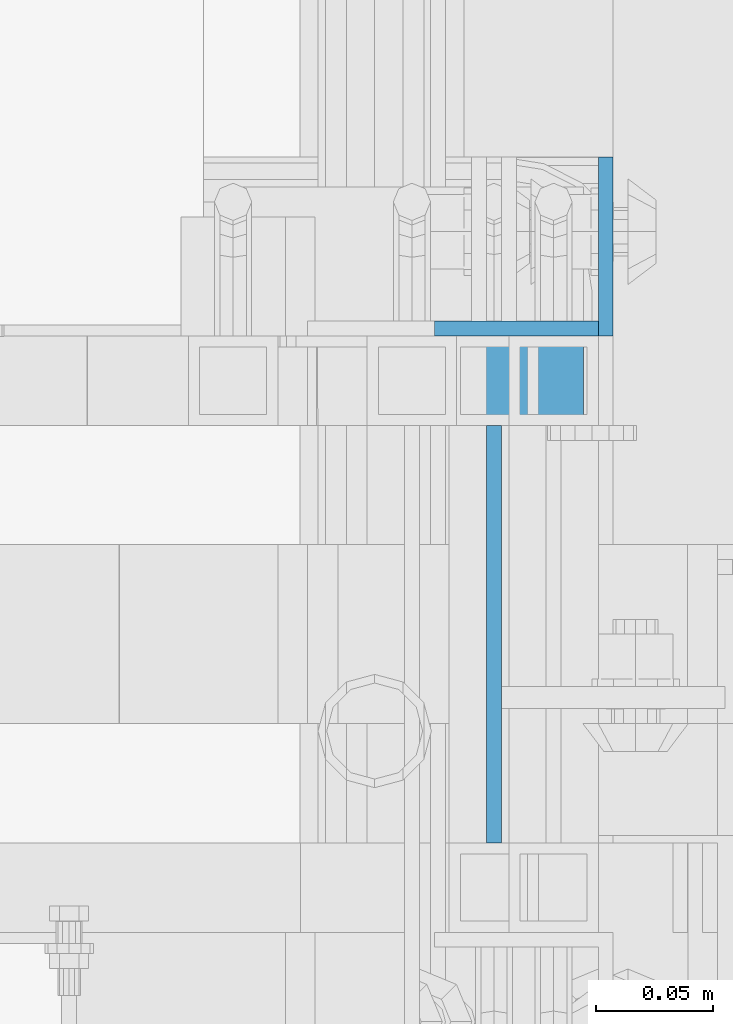
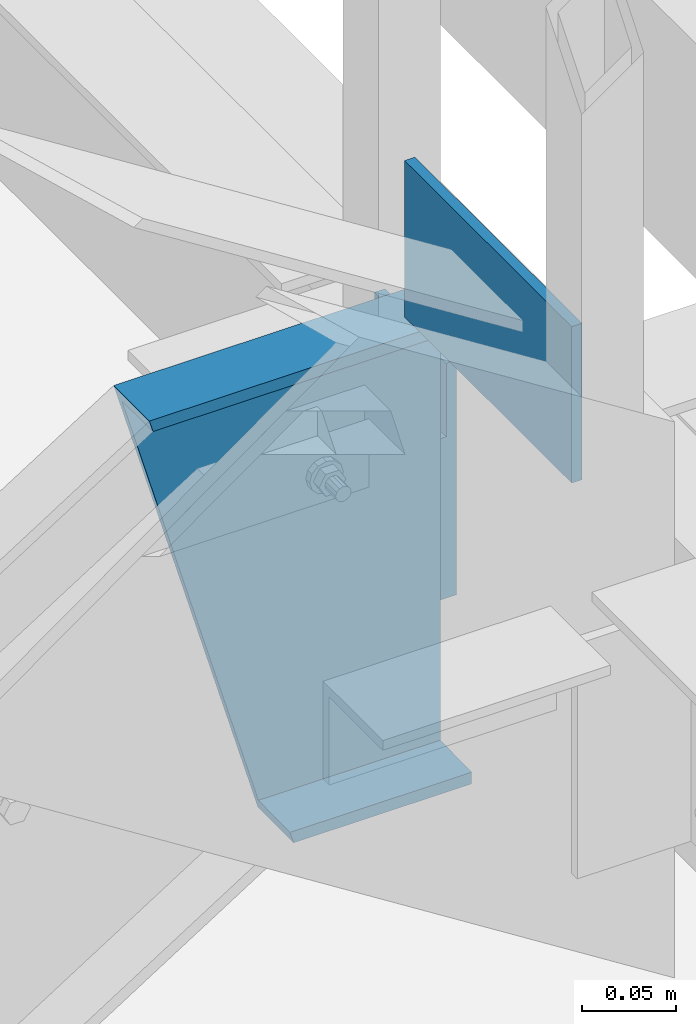
# One storey, part 1200 of 1876: 3 beams, 2 elements without a shape of their own.
"""IFC2X3 building model written with IfcOpenShell, lengths in millimetres."""

from ifc_helpers import new_model, si_unit, frame, origin_with_axes, place, context, subcontext, project, spatial, faceted_brep, material, type_object, element, aggregate, save


model = new_model("IFC2X3")

# Units and contexts
model_context = context("Model", 3, precision=1e-05, world=origin_with_axes())
body_context = subcontext(model_context, "Body", "Model", "MODEL_VIEW")
ifc_project = project(units=[si_unit("LENGTHUNIT", "METRE", prefix="MILLI"), si_unit("AREAUNIT", "SQUARE_METRE"), si_unit("VOLUMEUNIT", "CUBIC_METRE"), si_unit("MASSUNIT", "GRAM", prefix="KILO"), si_unit("TIMEUNIT", "SECOND"), si_unit("PLANEANGLEUNIT", "RADIAN"), si_unit("SOLIDANGLEUNIT", "STERADIAN"), si_unit("THERMODYNAMICTEMPERATUREUNIT", "DEGREE_CELSIUS"), si_unit("LUMINOUSINTENSITYUNIT", "LUMEN")], contexts=[model_context])

# Site, building, storey
site_placement = place(None, origin_with_axes())
site = spatial("IfcSite", under=ifc_project, at=site_placement, CompositionType="ELEMENT")
building_placement = place(site_placement, origin_with_axes())
building = spatial("IfcBuilding", under=site, at=building_placement, Name="Undefined", CompositionType="ELEMENT")
storey_placement = place(building_placement, origin_with_axes())
storey = spatial("IfcBuildingStorey", under=building, at=storey_placement, Name="Undefined", CompositionType="ELEMENT", Elevation=0.0)

# Assembly, beam
assembly_1_placement = place(storey_placement, origin_with_axes())
assembly_1 = element("IfcElementAssembly", 1, at=assembly_1_placement, inside=storey, Name="RAIL", AssemblyPlace="NOTDEFINED", PredefinedType="RIGID_FRAME")
ifc_material = material(Name="STEEL/A36")
beam_type_1 = type_object("IfcBeamType", PredefinedType="NOTDEFINED")
beam_1_placement = place(assembly_1_placement, frame((6248.39999930583, -5753.10000038053, 2393.18362061127), z_axis=(0.0, 0.0, 1.0), x_axis=(0.0, -1.0, 0.0)))
beam_1 = element("IfcBeam", 2, at=beam_1_placement, type_object=beam_type_1, material=ifc_material, Name="PLATE", context=body_context, shape_type="Brep", body=[
    faceted_brep([(0.0, 3.17500000000018, -50.8000000000002), (0.0, 3.17500000000018, 50.8000000000002), (177.799998770143, 3.1750000000111, 50.8000000000866), (177.799998770101, 3.1750000000111, -50.7999999999138), (0.0, -3.17500000000018, 50.8000000000002), (177.799998770144, -3.17499999998881, 50.8000000000866), (0.0, -3.17500000000018, -50.8000000000002), (177.799998770101, -3.17499999998881, -50.7999999999138)], [[[0, 1, 2, 3]], [[1, 4, 5, 2]], [[4, 6, 7, 5]], [[6, 0, 3, 7]], [[5, 7, 3, 2]], [[6, 4, 1, 0]]]),
])
aggregate(assembly_1, [beam_1])

# Assembly, beams
assembly_2_placement = place(storey_placement, origin_with_axes())
assembly_2 = element("IfcElementAssembly", 3, at=assembly_2_placement, inside=storey, Name="STRINGER", AssemblyPlace="NOTDEFINED", PredefinedType="RIGID_FRAME")
beam_type_2 = type_object("IfcBeamType", Name="L3X3X1/4", PredefinedType="NOTDEFINED")
beam_2_placement = place(assembly_2_placement, frame((6261.10000038163, -5676.90000121077, 2272.53362013306), z_axis=(-1.0, 0.0, 0.0), x_axis=(0.0, 0.0, -1.0)))
beam_2 = element("IfcBeam", 4, at=beam_2_placement, type_object=beam_type_2, material=ifc_material, Name="ANGLE", ObjectType="L3X3X1/4", context=body_context, shape_type="Brep", body=[
    faceted_brep([(47.6249994560144, 31.75, -31.75), (47.6249994560144, 38.1000000000004, -31.7499988043019), (0.0, 38.1000000000004, -31.7499984732442), (0.0, 31.75, -31.75), (47.6249994434002, 31.75, 38.0999996698192), (47.6249994434002, 38.1000000000004, 38.1000000000004), (152.4, 31.75, -31.75), (152.4, 31.75, 38.0999999999999), (0.0, -38.1000000000004, -31.75), (0.0, -38.1000000000004, -38.1), (152.4, -38.1000000000004, -38.1), (152.4, -38.1000000000004, -31.75), (0.0, 38.1000000000004, -38.1), (152.4, 38.1000000000004, -38.1), (152.4, 38.1000000000004, 38.1), (0.0, -15.5999984947448, -31.75)], [[[0, 1, 2, 3]], [[4, 5, 1, 0]], [[6, 7, 4, 0]], [[8, 9, 10, 11]], [[9, 12, 13, 10]], [[7, 6, 11, 10, 13, 14]], [[0, 3, 15, 8, 11, 6]], [[12, 9, 8, 15, 3, 2]], [[14, 13, 12, 2, 1, 5]], [[7, 14, 5, 4]]]),
])
beam_type_3 = type_object("IfcBeamType", Name="MC12X10.6", PredefinedType="NOTDEFINED")
beam_3_placement = place(assembly_2_placement, frame((6088.62272863529, -5734.05000121077, 2177.28362013306), z_axis=(0.0, 0.0, 1.0), x_axis=(1.0, 0.0, 0.0)))
beam_3 = element("IfcBeam", 5, at=beam_3_placement, type_object=beam_type_3, material=ifc_material, Name="STRINGER", ObjectType="MC12X10.6", context=body_context, shape_type="Brep", body=[
    faceted_brep([(88.527264823621, 19.0500000000002, -152.4), (-1.68647966347635e-06, 19.0500000000002, 152.400000000001), (197.877271746326, 19.0500000000002, 152.4), (197.877271746326, 19.0500000000002, -152.4), (-1.68647966347635e-06, -19.0500000000002, 152.400000000001), (197.877271746326, -19.0500000000002, 152.4), (2.19529173483147, -19.0500000000002, 144.841595), (197.877271746326, -19.0500000000002, 144.841595), (2.38797685967643, 14.2875000000004, 144.17817875), (197.877271746326, 14.2875000000004, 144.17817875), (86.1392879629268, 14.2875000000004, -144.17817875), (197.877271746326, 14.2875000000004, -144.17817875), (86.3319730877715, -19.0500000000002, -144.841595), (197.877271746326, -19.0500000000002, -144.841595), (88.527264823621, -19.0500000000002, -152.4), (197.877271746326, -19.0500000000002, -152.4)], [[[0, 1, 2, 3]], [[1, 4, 5, 2]], [[4, 6, 7, 5]], [[6, 8, 9, 7]], [[8, 10, 11, 9]], [[10, 12, 13, 11]], [[12, 14, 15, 13]], [[14, 0, 3, 15]], [[5, 7, 9, 11, 13, 15, 3, 2]], [[14, 12, 10, 8, 6, 4, 1, 0]]]),
])
aggregate(assembly_2, [beam_2, beam_3])

save(model, "model.ifc")
